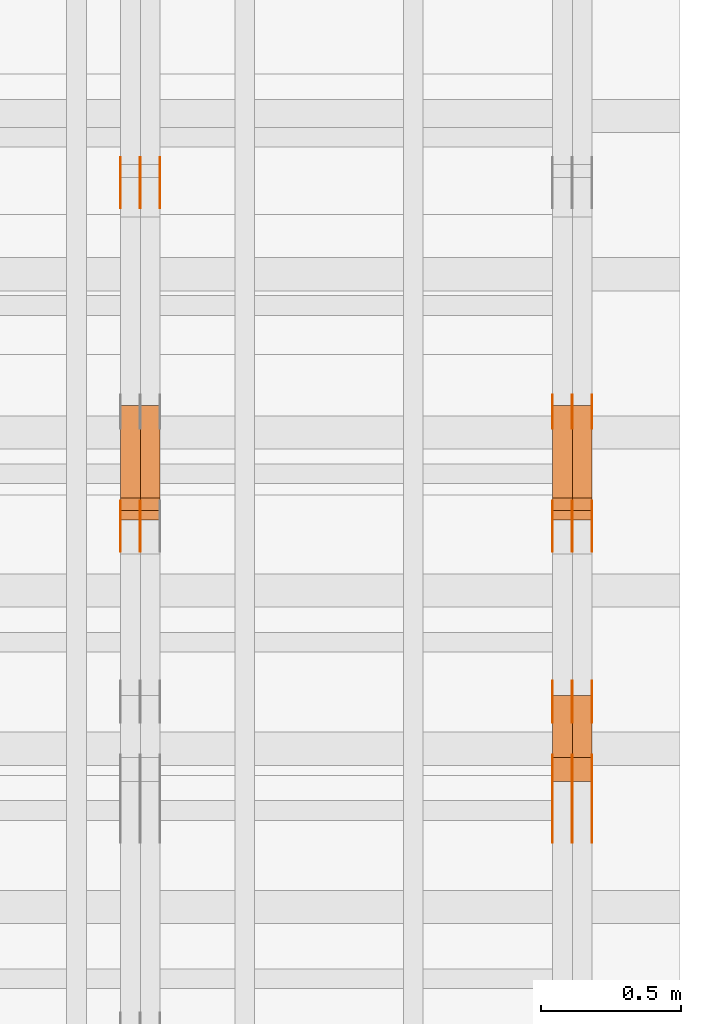
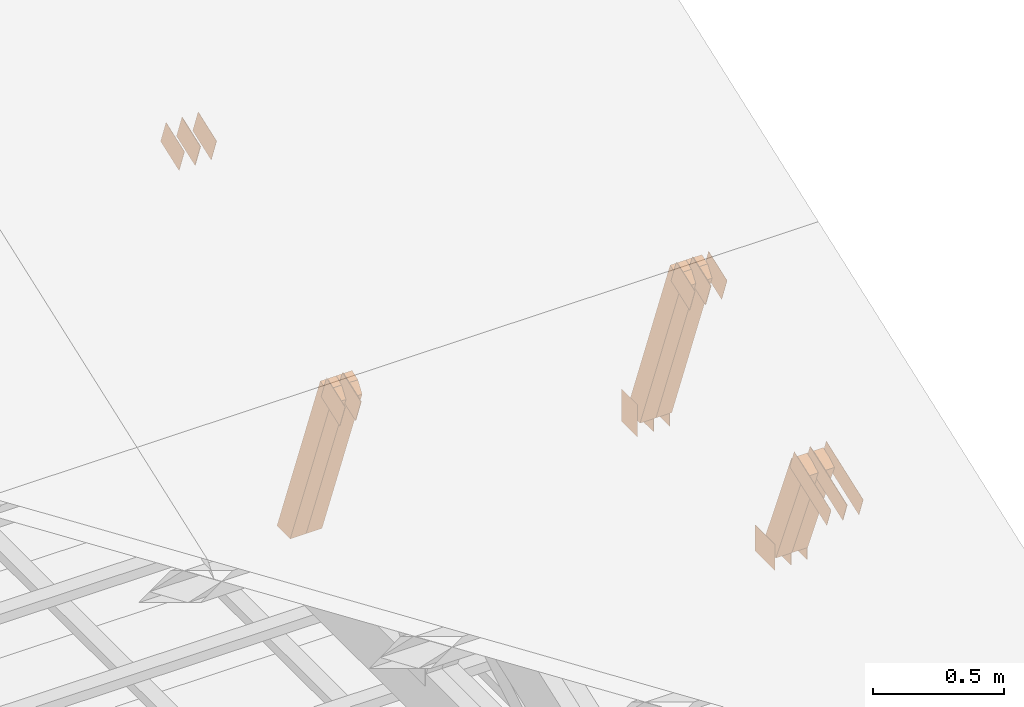
# One storey, part 154 of 189: 29 proxies.
"""IFC2X3 building model written with IfcOpenShell, lengths in millimetres."""

from ifc_helpers import new_model, entity, si_unit, converted_unit, derived_unit, direction, frame, frame_2d, origin, origin_2d_with_axis, place, context, subcontext, project, spatial, polyline, rectangle, outline, extrude, source, transform, mapped, material, type_object, type_shapes, element, save


model = new_model("IFC2X3")

# Units and contexts
model_context = context("Model", 3, precision=0.01, world=origin(), true_north=direction((6.12303176911189e-17, 1.0)))
body_context = subcontext(model_context, "Body", "Model", "MODEL_VIEW")
ifc_project = project(units=[si_unit("LENGTHUNIT", "METRE", prefix="MILLI"), si_unit("AREAUNIT", "SQUARE_METRE"), si_unit("VOLUMEUNIT", "CUBIC_METRE"), converted_unit("PLANEANGLEUNIT", "DEGREE", entity("IfcRatioMeasure", 0.0174532925199433), si_unit("PLANEANGLEUNIT", "RADIAN"), dimensions=[0, 0, 0, 0, 0, 0, 0]), si_unit("MASSUNIT", "GRAM", prefix="KILO"), derived_unit("MASSDENSITYUNIT", [(si_unit("MASSUNIT", "GRAM", prefix="KILO"), 1), (si_unit("LENGTHUNIT", "METRE"), -3)]), si_unit("TIMEUNIT", "SECOND"), si_unit("FREQUENCYUNIT", "HERTZ"), si_unit("THERMODYNAMICTEMPERATUREUNIT", "DEGREE_CELSIUS"), derived_unit("THERMALTRANSMITTANCEUNIT", [(si_unit("MASSUNIT", "GRAM", prefix="KILO"), 1), (si_unit("THERMODYNAMICTEMPERATUREUNIT", "KELVIN"), -1), (si_unit("TIMEUNIT", "SECOND"), -3)]), derived_unit("VOLUMETRICFLOWRATEUNIT", [(si_unit("LENGTHUNIT", "METRE"), 3), (si_unit("TIMEUNIT", "SECOND"), -1)]), si_unit("ELECTRICCURRENTUNIT", "AMPERE"), si_unit("ELECTRICVOLTAGEUNIT", "VOLT"), si_unit("POWERUNIT", "WATT"), si_unit("FORCEUNIT", "NEWTON"), si_unit("ILLUMINANCEUNIT", "LUX"), si_unit("LUMINOUSFLUXUNIT", "LUMEN"), si_unit("LUMINOUSINTENSITYUNIT", "CANDELA"), derived_unit("USERDEFINED", [(si_unit("MASSUNIT", "GRAM", prefix="KILO"), -1), (si_unit("LENGTHUNIT", "METRE"), -2), (si_unit("TIMEUNIT", "SECOND"), 3), (si_unit("LUMINOUSFLUXUNIT", "LUMEN"), 1)]), derived_unit("LINEARVELOCITYUNIT", [(si_unit("LENGTHUNIT", "METRE"), 1), (si_unit("TIMEUNIT", "SECOND"), -1)]), si_unit("PRESSUREUNIT", "PASCAL"), derived_unit("USERDEFINED", [(si_unit("LENGTHUNIT", "METRE"), -2), (si_unit("MASSUNIT", "GRAM", prefix="KILO"), 1), (si_unit("TIMEUNIT", "SECOND"), -2)])], contexts=[model_context])

# Site, building, storey
site_placement = place(None, origin())
site = spatial("IfcSite", under=ifc_project, at=site_placement, CompositionType="ELEMENT")
building_placement = place(site_placement, origin())
building = spatial("IfcBuilding", under=site, at=building_placement, CompositionType="ELEMENT")
storey_placement = place(building_placement, origin())
storey = spatial("IfcBuildingStorey", under=building, at=storey_placement, Name="Default", CompositionType="ELEMENT", Elevation=0.0)

# Proxies
ifc_material_1 = material(Name="IfcSurfaceStyle #278800")
building_element_proxy_type_1 = type_object("IfcBuildingElementProxyType", PredefinedType="NOTDEFINED", material=ifc_material_1)
shared_shape_1 = source(origin(), body_context, "Body", "SweptSolid", [
    extrude(rectangle(XDim=150.0, YDim=120.0, at=frame_2d((1.4210854715202e-14, -7.105427357601e-15), x_axis=(1.0, 0.0))), frame((75.0, 60.0004961323721, 0.0), z_axis=(0.0, 0.0, 1.0), x_axis=(-1.0, 0.0, 0.0)), (0.0, 0.0, 1.0), 1.3),
])
type_shapes(building_element_proxy_type_1, [shared_shape_1])
proxy_1_placement = place(building_placement, frame((49841.3, 2940.99169136763, 170.0), z_axis=(-1.0, 0.0, 0.0), x_axis=(0.0, 0.0, 1.0)))
element("IfcBuildingElementProxy", 1, at=proxy_1_placement, inside=storey, type_object=building_element_proxy_type_1, material=ifc_material_1, context=body_context, shape_type="MappedRepresentation", body=[
    mapped(shared_shape_1, transform((0.0, 0.0, 0.0), scale=1.0)),
])
ifc_material_2 = material(Name="IfcSurfaceStyle #278743")
building_element_proxy_type_2 = type_object("IfcBuildingElementProxyType", PredefinedType="NOTDEFINED", material=ifc_material_2)
shared_shape_2 = source(origin(), body_context, "Body", "SweptSolid", [
    extrude(rectangle(XDim=150.0, YDim=120.0, at=frame_2d((1.4210854715202e-14, -7.105427357601e-15), x_axis=(1.0, 0.0))), frame((75.0, 60.0004961323721, 0.0), z_axis=(0.0, 0.0, 1.0), x_axis=(-1.0, 0.0, 0.0)), (0.0, 0.0, 1.0), 1.29999999999999),
])
type_shapes(building_element_proxy_type_2, [shared_shape_2])
proxy_2_placement = place(building_placement, frame((49770.0, 2940.99169136763, 170.0), z_axis=(-1.0, 0.0, 0.0), x_axis=(0.0, 0.0, 1.0)))
element("IfcBuildingElementProxy", 2, at=proxy_2_placement, inside=storey, type_object=building_element_proxy_type_2, material=ifc_material_2, context=body_context, shape_type="MappedRepresentation", body=[
    mapped(shared_shape_2, transform((0.0, 0.0, 0.0), scale=1.0)),
])
ifc_material_3 = material(Name="IfcSurfaceStyle #278686")
building_element_proxy_type_3 = type_object("IfcBuildingElementProxyType", PredefinedType="NOTDEFINED", material=ifc_material_3)
shared_shape_3 = source(origin(), body_context, "Body", "SweptSolid", [
    extrude(rectangle(XDim=150.0, YDim=120.0, at=frame_2d((1.4210854715202e-14, -7.105427357601e-15), x_axis=(1.0, 0.0))), frame((75.0, 60.0004961323721, 0.0), z_axis=(0.0, 0.0, 1.0), x_axis=(-1.0, 0.0, 0.0)), (0.0, 0.0, 1.0), 1.29999999999999),
])
type_shapes(building_element_proxy_type_3, [shared_shape_3])
proxy_3_placement = place(building_placement, frame((49771.3, 2940.99169136763, 170.0), z_axis=(-1.0, 0.0, 0.0), x_axis=(0.0, 0.0, 1.0)))
element("IfcBuildingElementProxy", 3, at=proxy_3_placement, inside=storey, type_object=building_element_proxy_type_3, material=ifc_material_3, context=body_context, shape_type="MappedRepresentation", body=[
    mapped(shared_shape_3, transform((0.0, 0.0, 0.0), scale=1.0)),
])
ifc_material_4 = material(Name="IfcSurfaceStyle #278629")
building_element_proxy_type_4 = type_object("IfcBuildingElementProxyType", PredefinedType="NOTDEFINED", material=ifc_material_4)
shared_shape_4 = source(origin(), body_context, "Body", "SweptSolid", [
    extrude(rectangle(XDim=150.0, YDim=120.0, at=frame_2d((1.4210854715202e-14, -7.105427357601e-15), x_axis=(1.0, 0.0))), frame((75.0, 60.0004961323721, 0.0), z_axis=(0.0, 0.0, 1.0), x_axis=(-1.0, 0.0, 0.0)), (0.0, 0.0, 1.0), 1.29999999999999),
])
type_shapes(building_element_proxy_type_4, [shared_shape_4])
proxy_4_placement = place(building_placement, frame((49700.0, 2940.99169136763, 170.0), z_axis=(-1.0, 0.0, 0.0), x_axis=(0.0, 0.0, 1.0)))
element("IfcBuildingElementProxy", 4, at=proxy_4_placement, inside=storey, type_object=building_element_proxy_type_4, material=ifc_material_4, context=body_context, shape_type="MappedRepresentation", body=[
    mapped(shared_shape_4, transform((0.0, 0.0, 0.0), scale=1.0)),
])
ifc_material_5 = material(Name="IfcSurfaceStyle #278572")
building_element_proxy_type_5 = type_object("IfcBuildingElementProxyType", PredefinedType="NOTDEFINED", material=ifc_material_5)
shared_shape_5 = source(origin(), body_context, "Body", "SweptSolid", [
    extrude(outline(polyline([(-75.0008071857483, -59.9999039432187), (75.0002916555677, -59.9999039432187), (75.0008280609982, 59.9999039432187), (-75.0003125308176, 59.9999039432187), (-75.0008071857483, -59.9999039432187)])), frame((75.0008280609982, 60.0002349219685, 0.0), z_axis=(0.0, 0.0, 1.0), x_axis=(-1.0, 0.0, 0.0)), (0.0, 0.0, 1.0), 1.3),
])
type_shapes(building_element_proxy_type_5, [shared_shape_5])
proxy_5_placement = place(building_placement, frame((49841.3, 2502.466796875, 1113.95080566406), z_axis=(-1.0, 0.0, 0.0), x_axis=(0.0, 0.939692620785908, 0.342020143325669)))
element("IfcBuildingElementProxy", 5, at=proxy_5_placement, inside=storey, type_object=building_element_proxy_type_5, material=ifc_material_5, context=body_context, shape_type="MappedRepresentation", body=[
    mapped(shared_shape_5, transform((0.0, 0.0, 0.0), scale=1.0)),
])
ifc_material_6 = material(Name="IfcSurfaceStyle #278515")
building_element_proxy_type_6 = type_object("IfcBuildingElementProxyType", PredefinedType="NOTDEFINED", material=ifc_material_6)
shared_shape_6 = source(origin(), body_context, "Body", "SweptSolid", [
    extrude(outline(polyline([(-75.0008071857483, -59.9999039432187), (75.0002916555677, -59.9999039432187), (75.0008280609982, 59.9999039432187), (-75.0003125308176, 59.9999039432187), (-75.0008071857483, -59.9999039432187)])), frame((75.0008280609982, 60.0002349219685, 0.0), z_axis=(0.0, 0.0, 1.0), x_axis=(-1.0, 0.0, 0.0)), (0.0, 0.0, 1.0), 1.29999999999999),
])
type_shapes(building_element_proxy_type_6, [shared_shape_6])
proxy_6_placement = place(building_placement, frame((49770.0, 2502.466796875, 1113.95080566406), z_axis=(-1.0, 0.0, 0.0), x_axis=(0.0, 0.939692620785908, 0.342020143325669)))
element("IfcBuildingElementProxy", 6, at=proxy_6_placement, inside=storey, type_object=building_element_proxy_type_6, material=ifc_material_6, context=body_context, shape_type="MappedRepresentation", body=[
    mapped(shared_shape_6, transform((0.0, 0.0, 0.0), scale=1.0)),
])
ifc_material_7 = material(Name="IfcSurfaceStyle #278458")
building_element_proxy_type_7 = type_object("IfcBuildingElementProxyType", PredefinedType="NOTDEFINED", material=ifc_material_7)
shared_shape_7 = source(origin(), body_context, "Body", "SweptSolid", [
    extrude(outline(polyline([(-75.0008071857483, -59.9999039432187), (75.0002916555677, -59.9999039432187), (75.0008280609982, 59.9999039432187), (-75.0003125308176, 59.9999039432187), (-75.0008071857483, -59.9999039432187)])), frame((75.0008280609982, 60.0002349219685, 0.0), z_axis=(0.0, 0.0, 1.0), x_axis=(-1.0, 0.0, 0.0)), (0.0, 0.0, 1.0), 1.29999999999999),
])
type_shapes(building_element_proxy_type_7, [shared_shape_7])
proxy_7_placement = place(building_placement, frame((49771.3, 2502.466796875, 1113.95080566406), z_axis=(-1.0, 0.0, 0.0), x_axis=(0.0, 0.939692620785908, 0.342020143325669)))
element("IfcBuildingElementProxy", 7, at=proxy_7_placement, inside=storey, type_object=building_element_proxy_type_7, material=ifc_material_7, context=body_context, shape_type="MappedRepresentation", body=[
    mapped(shared_shape_7, transform((0.0, 0.0, 0.0), scale=1.0)),
])
ifc_material_8 = material(Name="IfcSurfaceStyle #278401")
building_element_proxy_type_8 = type_object("IfcBuildingElementProxyType", PredefinedType="NOTDEFINED", material=ifc_material_8)
shared_shape_8 = source(origin(), body_context, "Body", "SweptSolid", [
    extrude(outline(polyline([(-75.0008071857483, -59.9999039432187), (75.0002916555677, -59.9999039432187), (75.0008280609982, 59.9999039432187), (-75.0003125308176, 59.9999039432187), (-75.0008071857483, -59.9999039432187)])), frame((75.0008280609982, 60.0002349219685, 0.0), z_axis=(0.0, 0.0, 1.0), x_axis=(-1.0, 0.0, 0.0)), (0.0, 0.0, 1.0), 1.29999999999999),
])
type_shapes(building_element_proxy_type_8, [shared_shape_8])
proxy_8_placement = place(building_placement, frame((49700.0, 2502.466796875, 1113.95080566406), z_axis=(-1.0, 0.0, 0.0), x_axis=(0.0, 0.939692620785908, 0.342020143325669)))
element("IfcBuildingElementProxy", 8, at=proxy_8_placement, inside=storey, type_object=building_element_proxy_type_8, material=ifc_material_8, context=body_context, shape_type="MappedRepresentation", body=[
    mapped(shared_shape_8, transform((0.0, 0.0, 0.0), scale=1.0)),
])
ifc_material_9 = material(Name="IfcSurfaceStyle #277888")
building_element_proxy_type_9 = type_object("IfcBuildingElementProxyType", PredefinedType="NOTDEFINED", material=ifc_material_9)
shared_shape_9 = source(origin(), body_context, "Body", "SweptSolid", [
    extrude(rectangle(XDim=150.0, YDim=120.0, at=origin_2d_with_axis()), frame((75.0004757715869, 60.0, 0.0), z_axis=(0.0, 0.0, 1.0), x_axis=(-1.0, 0.0, 0.0)), (0.0, 0.0, 1.0), 1.3),
])
type_shapes(building_element_proxy_type_9, [shared_shape_9])
proxy_9_placement = place(building_placement, frame((49841.3, 1892.68702422841, 305.0), z_axis=(-1.0, 0.0, 0.0), x_axis=(0.0, 1.0, 0.0)))
element("IfcBuildingElementProxy", 9, at=proxy_9_placement, inside=storey, type_object=building_element_proxy_type_9, material=ifc_material_9, context=body_context, shape_type="MappedRepresentation", body=[
    mapped(shared_shape_9, transform((0.0, 0.0, 0.0), scale=1.0)),
])
ifc_material_10 = material(Name="IfcSurfaceStyle #277831")
building_element_proxy_type_10 = type_object("IfcBuildingElementProxyType", PredefinedType="NOTDEFINED", material=ifc_material_10)
shared_shape_10 = source(origin(), body_context, "Body", "SweptSolid", [
    extrude(rectangle(XDim=150.0, YDim=120.0, at=origin_2d_with_axis()), frame((75.0004757715869, 60.0, 0.0), z_axis=(0.0, 0.0, 1.0), x_axis=(-1.0, 0.0, 0.0)), (0.0, 0.0, 1.0), 1.29999999999999),
])
type_shapes(building_element_proxy_type_10, [shared_shape_10])
proxy_10_placement = place(building_placement, frame((49770.0, 1892.68702422841, 305.0), z_axis=(-1.0, 0.0, 0.0), x_axis=(0.0, 1.0, 0.0)))
element("IfcBuildingElementProxy", 10, at=proxy_10_placement, inside=storey, type_object=building_element_proxy_type_10, material=ifc_material_10, context=body_context, shape_type="MappedRepresentation", body=[
    mapped(shared_shape_10, transform((0.0, 0.0, 0.0), scale=1.0)),
])
ifc_material_11 = material(Name="IfcSurfaceStyle #277774")
building_element_proxy_type_11 = type_object("IfcBuildingElementProxyType", PredefinedType="NOTDEFINED", material=ifc_material_11)
shared_shape_11 = source(origin(), body_context, "Body", "SweptSolid", [
    extrude(rectangle(XDim=150.0, YDim=120.0, at=origin_2d_with_axis()), frame((75.0004757715869, 60.0, 0.0), z_axis=(0.0, 0.0, 1.0), x_axis=(-1.0, 0.0, 0.0)), (0.0, 0.0, 1.0), 1.29999999999999),
])
type_shapes(building_element_proxy_type_11, [shared_shape_11])
proxy_11_placement = place(building_placement, frame((49771.3, 1892.68702422841, 305.0), z_axis=(-1.0, 0.0, 0.0), x_axis=(0.0, 1.0, 0.0)))
element("IfcBuildingElementProxy", 11, at=proxy_11_placement, inside=storey, type_object=building_element_proxy_type_11, material=ifc_material_11, context=body_context, shape_type="MappedRepresentation", body=[
    mapped(shared_shape_11, transform((0.0, 0.0, 0.0), scale=1.0)),
])
ifc_material_12 = material(Name="IfcSurfaceStyle #277717")
building_element_proxy_type_12 = type_object("IfcBuildingElementProxyType", PredefinedType="NOTDEFINED", material=ifc_material_12)
shared_shape_12 = source(origin(), body_context, "Body", "SweptSolid", [
    extrude(rectangle(XDim=150.0, YDim=120.0, at=origin_2d_with_axis()), frame((75.0004757715869, 60.0, 0.0), z_axis=(0.0, 0.0, 1.0), x_axis=(-1.0, 0.0, 0.0)), (0.0, 0.0, 1.0), 1.29999999999999),
])
type_shapes(building_element_proxy_type_12, [shared_shape_12])
proxy_12_placement = place(building_placement, frame((49700.0, 1892.68702422841, 305.0), z_axis=(-1.0, 0.0, 0.0), x_axis=(0.0, 1.0, 0.0)))
element("IfcBuildingElementProxy", 12, at=proxy_12_placement, inside=storey, type_object=building_element_proxy_type_12, material=ifc_material_12, context=body_context, shape_type="MappedRepresentation", body=[
    mapped(shared_shape_12, transform((0.0, 0.0, 0.0), scale=1.0)),
])
ifc_material_13 = material(Name="IfcSurfaceStyle #277660")
building_element_proxy_type_13 = type_object("IfcBuildingElementProxyType", PredefinedType="NOTDEFINED", material=ifc_material_13)
shared_shape_13 = source(origin(), body_context, "Body", "SweptSolid", [
    extrude(outline(polyline([(-150.000217420008, -47.9999344162752), (150.000165800718, -47.9999344162752), (150.000227857633, 47.9999344162752), (-150.000176238343, 47.9999344162752), (-150.000217420008, -47.9999344162752)])), frame((150.000227857633, 48.0000430742566, 0.0), z_axis=(0.0, 0.0, 1.0), x_axis=(-1.0, 0.0, 0.0)), (0.0, 0.0, 1.0), 1.29999999999999),
])
type_shapes(building_element_proxy_type_13, [shared_shape_13])
proxy_13_placement = place(building_placement, frame((49841.3, 1464.46484375, 723.378723144533), z_axis=(-1.0, 0.0, 0.0), x_axis=(0.0, 0.939692620785908, 0.342020143325669)))
element("IfcBuildingElementProxy", 13, at=proxy_13_placement, inside=storey, type_object=building_element_proxy_type_13, material=ifc_material_13, context=body_context, shape_type="MappedRepresentation", body=[
    mapped(shared_shape_13, transform((0.0, 0.0, 0.0), scale=1.0)),
])
ifc_material_14 = material(Name="IfcSurfaceStyle #277603")
building_element_proxy_type_14 = type_object("IfcBuildingElementProxyType", PredefinedType="NOTDEFINED", material=ifc_material_14)
shared_shape_14 = source(origin(), body_context, "Body", "SweptSolid", [
    extrude(outline(polyline([(-150.000217420008, -47.9999344162752), (150.000165800718, -47.9999344162752), (150.000227857633, 47.9999344162752), (-150.000176238343, 47.9999344162752), (-150.000217420008, -47.9999344162752)])), frame((150.000227857633, 48.0000430742566, 0.0), z_axis=(0.0, 0.0, 1.0), x_axis=(-1.0, 0.0, 0.0)), (0.0, 0.0, 1.0), 1.29999999999998),
])
type_shapes(building_element_proxy_type_14, [shared_shape_14])
proxy_14_placement = place(building_placement, frame((49770.0, 1464.46484375, 723.378723144533), z_axis=(-1.0, 0.0, 0.0), x_axis=(0.0, 0.939692620785908, 0.342020143325669)))
element("IfcBuildingElementProxy", 14, at=proxy_14_placement, inside=storey, type_object=building_element_proxy_type_14, material=ifc_material_14, context=body_context, shape_type="MappedRepresentation", body=[
    mapped(shared_shape_14, transform((0.0, 0.0, 0.0), scale=1.0)),
])
ifc_material_15 = material(Name="IfcSurfaceStyle #277546")
building_element_proxy_type_15 = type_object("IfcBuildingElementProxyType", PredefinedType="NOTDEFINED", material=ifc_material_15)
shared_shape_15 = source(origin(), body_context, "Body", "SweptSolid", [
    extrude(outline(polyline([(-150.000217420008, -47.9999344162752), (150.000165800718, -47.9999344162752), (150.000227857633, 47.9999344162752), (-150.000176238343, 47.9999344162752), (-150.000217420008, -47.9999344162752)])), frame((150.000227857633, 48.0000430742566, 0.0), z_axis=(0.0, 0.0, 1.0), x_axis=(-1.0, 0.0, 0.0)), (0.0, 0.0, 1.0), 1.29999999999998),
])
type_shapes(building_element_proxy_type_15, [shared_shape_15])
proxy_15_placement = place(building_placement, frame((49771.3, 1464.46484375, 723.378723144533), z_axis=(-1.0, 0.0, 0.0), x_axis=(0.0, 0.939692620785908, 0.342020143325669)))
element("IfcBuildingElementProxy", 15, at=proxy_15_placement, inside=storey, type_object=building_element_proxy_type_15, material=ifc_material_15, context=body_context, shape_type="MappedRepresentation", body=[
    mapped(shared_shape_15, transform((0.0, 0.0, 0.0), scale=1.0)),
])
ifc_material_16 = material(Name="IfcSurfaceStyle #277489")
building_element_proxy_type_16 = type_object("IfcBuildingElementProxyType", PredefinedType="NOTDEFINED", material=ifc_material_16)
shared_shape_16 = source(origin(), body_context, "Body", "SweptSolid", [
    extrude(outline(polyline([(-150.000217420008, -47.9999344162752), (150.000165800718, -47.9999344162752), (150.000227857633, 47.9999344162752), (-150.000176238343, 47.9999344162752), (-150.000217420008, -47.9999344162752)])), frame((150.000227857633, 48.0000430742566, 0.0), z_axis=(0.0, 0.0, 1.0), x_axis=(-1.0, 0.0, 0.0)), (0.0, 0.0, 1.0), 1.29999999999998),
])
type_shapes(building_element_proxy_type_16, [shared_shape_16])
proxy_16_placement = place(building_placement, frame((49700.0, 1464.46484375, 723.378723144533), z_axis=(-1.0, 0.0, 0.0), x_axis=(0.0, 0.939692620785908, 0.342020143325669)))
element("IfcBuildingElementProxy", 16, at=proxy_16_placement, inside=storey, type_object=building_element_proxy_type_16, material=ifc_material_16, context=body_context, shape_type="MappedRepresentation", body=[
    mapped(shared_shape_16, transform((0.0, 0.0, 0.0), scale=1.0)),
])
ifc_material_17 = material(Name="IfcSurfaceStyle #271000")
building_element_proxy_type_17 = type_object("IfcBuildingElementProxyType", Name="T1-W14 270998", PredefinedType="NOTDEFINED", material=ifc_material_17)
shared_shape_17 = source(origin(), body_context, "Body", "SweptSolid", [
    extrude(outline(polyline([(-526.068269984593, -47.5004595774917), (341.27769108205, -47.5004595774917), (373.679499344758, 0.000392511719837607), (373.092506900368, 47.5002633216318), (-561.981427342584, 47.5002633216318), (-526.068269984593, -47.5004595774917)])), frame((373.67978783425, 47.5005221796964, 0.0), z_axis=(0.0, 0.0, 1.0), x_axis=(-1.0, 0.0, 0.0)), (0.0, 0.0, 1.0), 69.9999999999999),
])
type_shapes(building_element_proxy_type_17, [shared_shape_17])
proxy_17_placement = place(building_placement, frame((49840.0, 2693.38241954499, 1120.21215048788), z_axis=(-1.0, 0.0, 0.0), x_axis=(0.0, 0.353606472447916, -0.935394281916958)))
element("IfcBuildingElementProxy", 17, at=proxy_17_placement, inside=storey, type_object=building_element_proxy_type_17, material=ifc_material_17, Name="T1-W14", context=body_context, shape_type="MappedRepresentation", body=[
    mapped(shared_shape_17, transform((0.0, 0.0, 0.0), scale=1.0)),
])
ifc_material_18 = material(Name="IfcSurfaceStyle #270934")
building_element_proxy_type_18 = type_object("IfcBuildingElementProxyType", Name="T1-W14 270932", PredefinedType="NOTDEFINED", material=ifc_material_18)
shared_shape_18 = source(origin(), body_context, "Body", "SweptSolid", [
    extrude(outline(polyline([(-526.068269984593, -47.5004595774917), (341.27769108205, -47.5004595774917), (373.679499344758, 0.000392511719837607), (373.092506900368, 47.5002633216318), (-561.981427342584, 47.5002633216318), (-526.068269984593, -47.5004595774917)])), frame((373.67978783425, 47.5005221796964, 0.0), z_axis=(0.0, 0.0, 1.0), x_axis=(-1.0, 0.0, 0.0)), (0.0, 0.0, 1.0), 69.9999999999999),
])
type_shapes(building_element_proxy_type_18, [shared_shape_18])
proxy_18_placement = place(building_placement, frame((49770.0, 2693.38241954499, 1120.21215048788), z_axis=(-1.0, 0.0, 0.0), x_axis=(0.0, 0.353606472447916, -0.935394281916958)))
element("IfcBuildingElementProxy", 18, at=proxy_18_placement, inside=storey, type_object=building_element_proxy_type_18, material=ifc_material_18, Name="T1-W14", context=body_context, shape_type="MappedRepresentation", body=[
    mapped(shared_shape_18, transform((0.0, 0.0, 0.0), scale=1.0)),
])
ifc_material_19 = material(Name="IfcSurfaceStyle #270472")
building_element_proxy_type_19 = type_object("IfcBuildingElementProxyType", Name="T1-W15 270470", PredefinedType="NOTDEFINED", material=ifc_material_19)
shared_shape_19 = source(origin(), body_context, "Body", "SweptSolid", [
    extrude(outline(polyline([(-317.132720418368, -47.5005147440206), (220.445242566881, -47.5005147440206), (227.5021778825, -0.000126286009697951), (225.500088907744, 47.5005778870255), (-356.314788938758, 47.5005778870255), (-317.132720418368, -47.5005147440206)])), frame((227.5021778825, 47.5005778870255, 0.0), z_axis=(0.0, 0.0, 1.0), x_axis=(-1.0, 0.0, 0.0)), (0.0, 0.0, 1.0), 70.0),
])
type_shapes(building_element_proxy_type_19, [shared_shape_19])
proxy_19_placement = place(building_placement, frame((49840.0, 1767.47882447529, 784.714556181707), z_axis=(-1.0, 0.0, 0.0), x_axis=(0.0, 0.381283266795389, -0.924458257825542)))
element("IfcBuildingElementProxy", 19, at=proxy_19_placement, inside=storey, type_object=building_element_proxy_type_19, material=ifc_material_19, Name="T1-W15", context=body_context, shape_type="MappedRepresentation", body=[
    mapped(shared_shape_19, transform((0.0, 0.0, 0.0), scale=1.0)),
])
ifc_material_20 = material(Name="IfcSurfaceStyle #270406")
building_element_proxy_type_20 = type_object("IfcBuildingElementProxyType", Name="T1-W15 270404", PredefinedType="NOTDEFINED", material=ifc_material_20)
shared_shape_20 = source(origin(), body_context, "Body", "SweptSolid", [
    extrude(outline(polyline([(-317.132720418368, -47.5005147440206), (220.445242566881, -47.5005147440206), (227.5021778825, -0.000126286009697951), (225.500088907744, 47.5005778870255), (-356.314788938758, 47.5005778870255), (-317.132720418368, -47.5005147440206)])), frame((227.5021778825, 47.5005778870255, 0.0), z_axis=(0.0, 0.0, 1.0), x_axis=(-1.0, 0.0, 0.0)), (0.0, 0.0, 1.0), 70.0),
])
type_shapes(building_element_proxy_type_20, [shared_shape_20])
proxy_20_placement = place(building_placement, frame((49770.0, 1767.47882447529, 784.714556181707), z_axis=(-1.0, 0.0, 0.0), x_axis=(0.0, 0.381283266795389, -0.924458257825542)))
element("IfcBuildingElementProxy", 20, at=proxy_20_placement, inside=storey, type_object=building_element_proxy_type_20, material=ifc_material_20, Name="T1-W15", context=body_context, shape_type="MappedRepresentation", body=[
    mapped(shared_shape_20, transform((0.0, 0.0, 0.0), scale=1.0)),
])
ifc_material_21 = material(Name="IfcSurfaceStyle #263694")
building_element_proxy_type_21 = type_object("IfcBuildingElementProxyType", PredefinedType="NOTDEFINED", material=ifc_material_21)
shared_shape_21 = source(origin(), body_context, "Body", "SweptSolid", [
    extrude(outline(polyline([(-74.9994515581384, -59.9999039432178), (74.9998536965286, -59.9999039432178), (75.0003483514593, 59.9999039432178), (-75.0007504898495, 59.9999039432178), (-74.9994515581384, -59.9999039432178)])), frame((75.0003483514593, 60.0003496305408, 0.0), z_axis=(0.0, 0.0, 1.0), x_axis=(-1.0, 0.0, 0.0)), (0.0, 0.0, 1.0), 1.3),
])
type_shapes(building_element_proxy_type_21, [shared_shape_21])
proxy_21_placement = place(building_placement, frame((48301.3, 3726.8984375, 1559.607421875), z_axis=(-1.0, 0.0, 0.0), x_axis=(0.0, 0.939692620785908, 0.342020143325669)))
element("IfcBuildingElementProxy", 21, at=proxy_21_placement, inside=storey, type_object=building_element_proxy_type_21, material=ifc_material_21, context=body_context, shape_type="MappedRepresentation", body=[
    mapped(shared_shape_21, transform((0.0, 0.0, 0.0), scale=1.0)),
])
ifc_material_22 = material(Name="IfcSurfaceStyle #263637")
building_element_proxy_type_22 = type_object("IfcBuildingElementProxyType", PredefinedType="NOTDEFINED", material=ifc_material_22)
shared_shape_22 = source(origin(), body_context, "Body", "SweptSolid", [
    extrude(outline(polyline([(-74.9994515581384, -59.9999039432178), (74.9998536965286, -59.9999039432178), (75.0003483514593, 59.9999039432178), (-75.0007504898495, 59.9999039432178), (-74.9994515581384, -59.9999039432178)])), frame((75.0003483514593, 60.0003496305408, 0.0), z_axis=(0.0, 0.0, 1.0), x_axis=(-1.0, 0.0, 0.0)), (0.0, 0.0, 1.0), 1.29999999999999),
])
type_shapes(building_element_proxy_type_22, [shared_shape_22])
proxy_22_placement = place(building_placement, frame((48230.0, 3726.8984375, 1559.607421875), z_axis=(-1.0, 0.0, 0.0), x_axis=(0.0, 0.939692620785908, 0.342020143325669)))
element("IfcBuildingElementProxy", 22, at=proxy_22_placement, inside=storey, type_object=building_element_proxy_type_22, material=ifc_material_22, context=body_context, shape_type="MappedRepresentation", body=[
    mapped(shared_shape_22, transform((0.0, 0.0, 0.0), scale=1.0)),
])
ifc_material_23 = material(Name="IfcSurfaceStyle #263580")
building_element_proxy_type_23 = type_object("IfcBuildingElementProxyType", PredefinedType="NOTDEFINED", material=ifc_material_23)
shared_shape_23 = source(origin(), body_context, "Body", "SweptSolid", [
    extrude(outline(polyline([(-74.9994515581384, -59.9999039432178), (74.9998536965286, -59.9999039432178), (75.0003483514593, 59.9999039432178), (-75.0007504898495, 59.9999039432178), (-74.9994515581384, -59.9999039432178)])), frame((75.0003483514593, 60.0003496305408, 0.0), z_axis=(0.0, 0.0, 1.0), x_axis=(-1.0, 0.0, 0.0)), (0.0, 0.0, 1.0), 1.29999999999999),
])
type_shapes(building_element_proxy_type_23, [shared_shape_23])
proxy_23_placement = place(building_placement, frame((48231.3, 3726.8984375, 1559.607421875), z_axis=(-1.0, 0.0, 0.0), x_axis=(0.0, 0.939692620785908, 0.342020143325669)))
element("IfcBuildingElementProxy", 23, at=proxy_23_placement, inside=storey, type_object=building_element_proxy_type_23, material=ifc_material_23, context=body_context, shape_type="MappedRepresentation", body=[
    mapped(shared_shape_23, transform((0.0, 0.0, 0.0), scale=1.0)),
])
ifc_material_24 = material(Name="IfcSurfaceStyle #263523")
building_element_proxy_type_24 = type_object("IfcBuildingElementProxyType", PredefinedType="NOTDEFINED", material=ifc_material_24)
shared_shape_24 = source(origin(), body_context, "Body", "SweptSolid", [
    extrude(outline(polyline([(-74.9994515581384, -59.9999039432178), (74.9998536965286, -59.9999039432178), (75.0003483514593, 59.9999039432178), (-75.0007504898495, 59.9999039432178), (-74.9994515581384, -59.9999039432178)])), frame((75.0003483514593, 60.0003496305408, 0.0), z_axis=(0.0, 0.0, 1.0), x_axis=(-1.0, 0.0, 0.0)), (0.0, 0.0, 1.0), 1.29999999999999),
])
type_shapes(building_element_proxy_type_24, [shared_shape_24])
proxy_24_placement = place(building_placement, frame((48160.0, 3726.8984375, 1559.607421875), z_axis=(-1.0, 0.0, 0.0), x_axis=(0.0, 0.939692620785908, 0.342020143325669)))
element("IfcBuildingElementProxy", 24, at=proxy_24_placement, inside=storey, type_object=building_element_proxy_type_24, material=ifc_material_24, context=body_context, shape_type="MappedRepresentation", body=[
    mapped(shared_shape_24, transform((0.0, 0.0, 0.0), scale=1.0)),
])
ifc_material_25 = material(Name="IfcSurfaceStyle #262725")
building_element_proxy_type_25 = type_object("IfcBuildingElementProxyType", PredefinedType="NOTDEFINED", material=ifc_material_25)
shared_shape_25 = source(origin(), body_context, "Body", "SweptSolid", [
    extrude(outline(polyline([(-75.0008071857483, -59.9999039432187), (75.0002916555677, -59.9999039432187), (75.0008280609982, 59.9999039432187), (-75.0003125308176, 59.9999039432187), (-75.0008071857483, -59.9999039432187)])), frame((75.0008280609982, 60.0002349219685, 0.0), z_axis=(0.0, 0.0, 1.0), x_axis=(-1.0, 0.0, 0.0)), (0.0, 0.0, 1.0), 1.29999999999999),
])
type_shapes(building_element_proxy_type_25, [shared_shape_25])
proxy_25_placement = place(building_placement, frame((48230.0, 2502.466796875, 1113.95080566406), z_axis=(-1.0, 0.0, 0.0), x_axis=(0.0, 0.939692620785908, 0.342020143325669)))
element("IfcBuildingElementProxy", 25, at=proxy_25_placement, inside=storey, type_object=building_element_proxy_type_25, material=ifc_material_25, context=body_context, shape_type="MappedRepresentation", body=[
    mapped(shared_shape_25, transform((0.0, 0.0, 0.0), scale=1.0)),
])
ifc_material_26 = material(Name="IfcSurfaceStyle #262668")
building_element_proxy_type_26 = type_object("IfcBuildingElementProxyType", PredefinedType="NOTDEFINED", material=ifc_material_26)
shared_shape_26 = source(origin(), body_context, "Body", "SweptSolid", [
    extrude(outline(polyline([(-75.0008071857483, -59.9999039432187), (75.0002916555677, -59.9999039432187), (75.0008280609982, 59.9999039432187), (-75.0003125308176, 59.9999039432187), (-75.0008071857483, -59.9999039432187)])), frame((75.0008280609982, 60.0002349219685, 0.0), z_axis=(0.0, 0.0, 1.0), x_axis=(-1.0, 0.0, 0.0)), (0.0, 0.0, 1.0), 1.29999999999999),
])
type_shapes(building_element_proxy_type_26, [shared_shape_26])
proxy_26_placement = place(building_placement, frame((48231.3, 2502.466796875, 1113.95080566406), z_axis=(-1.0, 0.0, 0.0), x_axis=(0.0, 0.939692620785908, 0.342020143325669)))
element("IfcBuildingElementProxy", 26, at=proxy_26_placement, inside=storey, type_object=building_element_proxy_type_26, material=ifc_material_26, context=body_context, shape_type="MappedRepresentation", body=[
    mapped(shared_shape_26, transform((0.0, 0.0, 0.0), scale=1.0)),
])
ifc_material_27 = material(Name="IfcSurfaceStyle #262611")
building_element_proxy_type_27 = type_object("IfcBuildingElementProxyType", PredefinedType="NOTDEFINED", material=ifc_material_27)
shared_shape_27 = source(origin(), body_context, "Body", "SweptSolid", [
    extrude(outline(polyline([(-75.0008071857483, -59.9999039432187), (75.0002916555677, -59.9999039432187), (75.0008280609982, 59.9999039432187), (-75.0003125308176, 59.9999039432187), (-75.0008071857483, -59.9999039432187)])), frame((75.0008280609982, 60.0002349219685, 0.0), z_axis=(0.0, 0.0, 1.0), x_axis=(-1.0, 0.0, 0.0)), (0.0, 0.0, 1.0), 1.29999999999999),
])
type_shapes(building_element_proxy_type_27, [shared_shape_27])
proxy_27_placement = place(building_placement, frame((48160.0, 2502.466796875, 1113.95080566406), z_axis=(-1.0, 0.0, 0.0), x_axis=(0.0, 0.939692620785908, 0.342020143325669)))
element("IfcBuildingElementProxy", 27, at=proxy_27_placement, inside=storey, type_object=building_element_proxy_type_27, material=ifc_material_27, context=body_context, shape_type="MappedRepresentation", body=[
    mapped(shared_shape_27, transform((0.0, 0.0, 0.0), scale=1.0)),
])
ifc_material_28 = material(Name="IfcSurfaceStyle #255210")
building_element_proxy_type_28 = type_object("IfcBuildingElementProxyType", Name="T1-W14 255208", PredefinedType="NOTDEFINED", material=ifc_material_28)
shared_shape_28 = source(origin(), body_context, "Body", "SweptSolid", [
    extrude(outline(polyline([(-526.068269984593, -47.5004595774917), (341.27769108205, -47.5004595774917), (373.679499344758, 0.000392511719837607), (373.092506900368, 47.5002633216318), (-561.981427342584, 47.5002633216318), (-526.068269984593, -47.5004595774917)])), frame((373.67978783425, 47.5005221796964, 0.0), z_axis=(0.0, 0.0, 1.0), x_axis=(-1.0, 0.0, 0.0)), (0.0, 0.0, 1.0), 69.9999999999999),
])
type_shapes(building_element_proxy_type_28, [shared_shape_28])
proxy_28_placement = place(building_placement, frame((48300.0, 2693.38241954499, 1120.21215048788), z_axis=(-1.0, 0.0, 0.0), x_axis=(0.0, 0.353606472447916, -0.935394281916958)))
element("IfcBuildingElementProxy", 28, at=proxy_28_placement, inside=storey, type_object=building_element_proxy_type_28, material=ifc_material_28, Name="T1-W14", context=body_context, shape_type="MappedRepresentation", body=[
    mapped(shared_shape_28, transform((0.0, 0.0, 0.0), scale=1.0)),
])
ifc_material_29 = material(Name="IfcSurfaceStyle #255144")
building_element_proxy_type_29 = type_object("IfcBuildingElementProxyType", Name="T1-W14 255142", PredefinedType="NOTDEFINED", material=ifc_material_29)
shared_shape_29 = source(origin(), body_context, "Body", "SweptSolid", [
    extrude(outline(polyline([(-526.068269984593, -47.5004595774917), (341.27769108205, -47.5004595774917), (373.679499344758, 0.000392511719837607), (373.092506900368, 47.5002633216318), (-561.981427342584, 47.5002633216318), (-526.068269984593, -47.5004595774917)])), frame((373.67978783425, 47.5005221796964, 0.0), z_axis=(0.0, 0.0, 1.0), x_axis=(-1.0, 0.0, 0.0)), (0.0, 0.0, 1.0), 69.9999999999999),
])
type_shapes(building_element_proxy_type_29, [shared_shape_29])
proxy_29_placement = place(building_placement, frame((48230.0, 2693.38241954499, 1120.21215048788), z_axis=(-1.0, 0.0, 0.0), x_axis=(0.0, 0.353606472447916, -0.935394281916958)))
element("IfcBuildingElementProxy", 29, at=proxy_29_placement, inside=storey, type_object=building_element_proxy_type_29, material=ifc_material_29, Name="T1-W14", context=body_context, shape_type="MappedRepresentation", body=[
    mapped(shared_shape_29, transform((0.0, 0.0, 0.0), scale=1.0)),
])

save(model, "model.ifc")
